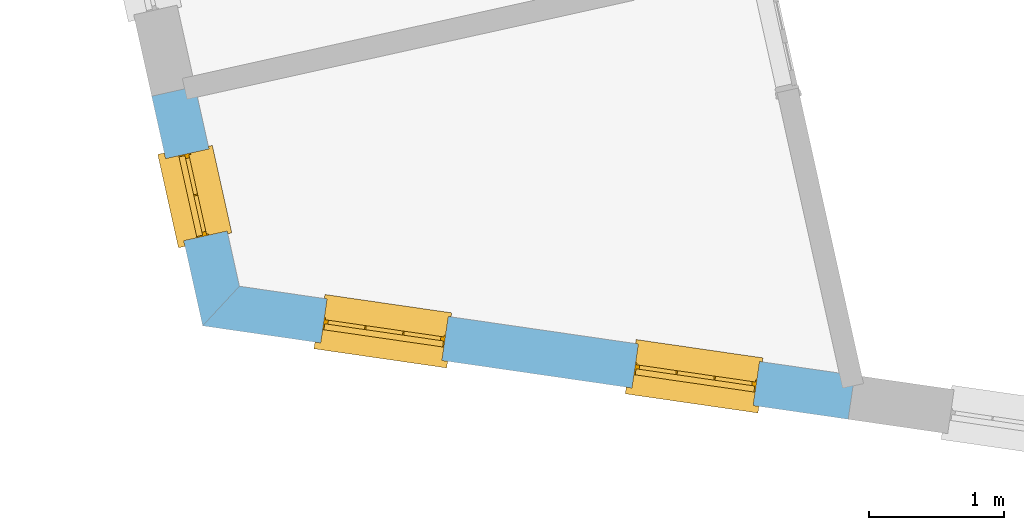
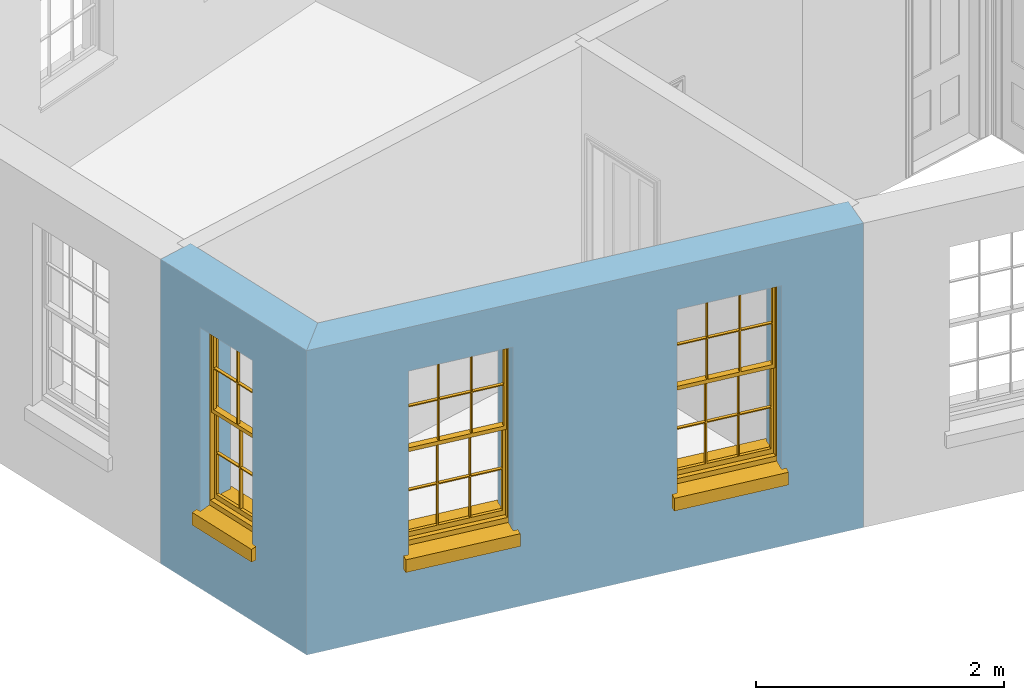
# One storey, part 2 of 10: 3 windows, 3 openings, plus 2 elements that do not belong to this part.
"""IFC2X3 building model written with IfcOpenShell, lengths in metres."""

from ifc_helpers import new_model, si_unit, frame, origin, place, context, subcontext, project, spatial, polyline, outline, extrude, faceted_brep, material, layer, layer_set, layer_usage, element, fill, save


model = new_model("IFC2X3")

# Units and contexts
model_context = context("Model", 3, world=origin())
body_context = subcontext(model_context, "Body", "Model", "MODEL_VIEW")
ifc_project = project(units=[si_unit("PLANEANGLEUNIT", "RADIAN"), si_unit("MASSUNIT", "GRAM", prefix="KILO"), si_unit("FORCEUNIT", "NEWTON", prefix="KILO"), si_unit("LENGTHUNIT", "METRE")], contexts=[model_context])

# Site, building, storey
site_placement = place(None, origin())
site = spatial("IfcSite", under=ifc_project, at=site_placement, CompositionType="ELEMENT")
building_placement = place(None, origin())
building = spatial("IfcBuilding", under=site, at=building_placement, Name="Building plot-16", CompositionType="ELEMENT")
storey_placement = place(None, frame((0.0, 0.0, 6.0)))
storey = spatial("IfcBuildingStorey", under=building, at=storey_placement, Name="Floor 1", CompositionType="ELEMENT", Elevation=6.0)

# Wall, opening, window
ifc_material = material(Name="Masonry")
ifc_layer = layer(ifc_material, 0.33, ventilated=False)
ifc_layer_set = layer_set([ifc_layer], Name="My Wall")
ifc_layer_usage = layer_usage(ifc_layer_set, "AXIS2", "NEGATIVE", 0.08)
wall_1_placement = place(storey_placement, origin())
wall_1 = element("IfcWallStandardCase", 1, at=wall_1_placement, inside=storey, material=ifc_layer_usage, Name="exterior", context=body_context, shape_type="SweptSolid", body=[
    extrude(outline(polyline([(87.6197813226672, 33.5557428221092), (87.2976082317312, 33.4842970421306), (87.6756142911979, 31.7797403754188), (87.9484434240576, 32.0736946856034), (87.6197813226672, 33.5557428221092)])), origin(), (0.0, 0.0, 1.0), 3.0),
])
opening_1_placement = place(storey_placement, frame((0.0, 0.0, 0.75)))
opening_1 = element("IfcOpeningElement", 2, at=opening_1_placement, cuts=wall_1, Name="Opening", ObjectType="Opening", context=body_context, shape_type="SweptSolid", body=[
    extrude(outline(polyline([(87.4002633796378, 33.0213903972391), (87.5355773568699, 32.4112140886482), (87.8577504478059, 32.4826598686268), (87.7224364705738, 33.0928361772177), (87.4002633796378, 33.0213903972391)])), origin(), (0.0, 0.0, 1.0), 1.82),
])
window_1_placement = place(storey_placement, frame((87.6443339030741, 33.075515988132, 0.75), z_axis=(0.0, 0.0, 1.0), x_axis=(0.135313977232144, -0.610176308590908, 0.0)))
window_1 = element("IfcWindow", 3, at=window_1_placement, inside=storey, Name="toilet outside window", OverallHeight=1.82, OverallWidth=0.625, context=body_context, shape_type="Brep", held_by="IfcProductRepresentation", body=[
    faceted_brep([(0.033125, -0.105, 0.975209), (0.01, -0.105, 0.975209), (0.033125, -0.105, 1.376042), (0.591875, -0.105, 0.975209), (0.591875, -0.105, 1.376042), (0.615, -0.105, 0.975209), (0.591875, -0.105, 1.386042), (0.591875, -0.105, 1.786875), (0.615, -0.105, 1.81), (0.033125, -0.105, 1.786875), (0.033125, -0.105, 1.386042), (0.01, -0.105, 1.81), (0.591875, -0.135, 1.376042), (0.591875, -0.135, 0.975209), (0.615, -0.135, 0.937083), (0.033125, -0.135, 1.786875), (0.01, -0.135, 1.81), (0.033125, -0.135, 1.386042), (0.01, -0.135, 0.937083), (0.033125, -0.135, 0.975209), (0.033125, -0.135, 1.376042), (0.591875, -0.135, 1.786875), (0.591875, -0.135, 1.386042), (0.615, -0.135, 1.81), (0.033125, -0.105, 0.937083), (0.01, -0.105, 0.937083), (0.033125, -0.105, 0.53625), (0.591875, -0.105, 0.937083), (0.591875, -0.105, 0.53625), (0.615, -0.105, 0.937083), (0.591875, -0.105, 0.52625), (0.591875, -0.105, 0.125417), (0.615, -0.105, 0.077167), (0.033125, -0.105, 0.125417), (0.033125, -0.105, 0.52625), (0.01, -0.105, 0.077167), (-0.0425, -0.25, 0.01), (-0.0425, -0.3, 0.001667), (0.0, -0.25, 0.01), (0.6675, -0.25, 0.01), (0.625, -0.25, 0.01), (0.6675, -0.3, 0.001667), (-0.02, 0.08, 0.077167), (0.0, 0.08, 0.077167), (-0.02, 0.11, 0.077167), (0.0, -0.06, 0.077167), (0.01, -0.06, 0.077167), (0.625, -0.06, 0.077167), (0.625, 0.08, 0.077167), (0.615, -0.06, 0.077167), (0.645, 0.08, 0.077167), (0.645, 0.11, 0.077167), (0.01, -0.075, 0.975209), (0.615, -0.075, 0.975209), (0.591875, -0.075, 0.125417), (0.591875, -0.075, 0.52625), (0.615, -0.075, 0.077167), (0.591875, -0.075, 0.53625), (0.591875, -0.075, 0.937083), (0.033125, -0.075, 0.125417), (0.01, -0.075, 0.077167), (0.033125, -0.075, 0.52625), (0.033125, -0.075, 0.937083), (0.033125, -0.075, 0.53625), (-0.02, 0.08, 0.052167), (-0.02, 0.11, 0.052167), (0.645, 0.11, 0.052167), (0.645, 0.08, 0.052167), (0.625, 0.08, 0.052167), (0.0, 0.08, 0.052167), (0.625, -0.15, 0.026667), (0.0, -0.15, 0.026667), (-0.0425, -0.3, -0.123333), (0.6675, -0.3, -0.123333), (-0.0425, -0.25, -0.123333), (0.6675, -0.25, -0.123333), (0.01, -0.06, 1.81), (0.615, -0.06, 1.81), (0.0, -0.06, 1.82), (0.625, -0.06, 1.82), (0.01, -0.15, 0.077167), (0.615, -0.15, 0.077167), (0.3175, -0.075, 0.53625), (0.3175, -0.105, 0.53625), (0.3175, -0.075, 0.52625), (0.3175, -0.075, 0.125417), (0.3075, -0.075, 0.125417), (0.3075, -0.075, 0.52625), (0.3075, -0.075, 0.53625), (0.3175, -0.075, 0.937083), (0.3075, -0.075, 0.937083), (0.3075, -0.105, 0.52625), (0.3075, -0.105, 0.125417), (0.3175, -0.105, 0.125417), (0.3175, -0.105, 0.52625), (0.3075, -0.105, 0.53625), (0.3075, -0.105, 0.937083), (0.3175, -0.105, 0.937083), (0.3075, -0.135, 1.386042), (0.3075, -0.135, 1.376042), (0.3175, -0.135, 1.376042), (0.3075, -0.135, 0.975209), (0.3175, -0.135, 0.975209), (0.3175, -0.135, 1.786875), (0.3075, -0.135, 1.786875), (0.3175, -0.135, 1.386042), (0.3175, -0.105, 1.386042), (0.3175, -0.105, 1.376042), (0.3075, -0.105, 1.386042), (0.3075, -0.105, 1.786875), (0.3175, -0.105, 1.786875), (0.3075, -0.105, 1.376042), (0.3175, -0.105, 0.975209), (0.3075, -0.105, 0.975209), (0.625, -0.15, 1.82), (0.615, -0.15, 1.81), (0.01, -0.15, 1.81), (0.0, -0.15, 1.82), (0.625, -0.25, 0.0), (0.0, -0.25, 0.0), (0.625, 0.08, 0.0), (0.0, 0.08, 0.0)], [[[0, 1, 2]], [[3, 4, 5]], [[6, 7, 8]], [[9, 10, 11]], [[12, 13, 14]], [[15, 16, 17]], [[18, 19, 20]], [[21, 22, 23]], [[24, 25, 26]], [[27, 28, 29]], [[30, 31, 32]], [[33, 34, 35]], [[14, 27, 29]], [[25, 24, 18]], [[36, 37, 38]], [[39, 40, 41]], [[42, 43, 44]], [[45, 46, 43]], [[47, 48, 49]], [[50, 51, 48]], [[1, 0, 52]], [[5, 53, 3]], [[54, 55, 56]], [[57, 58, 53]], [[59, 60, 61]], [[62, 63, 52]], [[48, 43, 46, 49]], [[51, 44, 43, 48]], [[64, 42, 44, 65]], [[65, 44, 51, 66]], [[66, 51, 50, 67]], [[65, 66, 68, 69]], [[60, 56, 49, 46]], [[70, 71, 38, 40]], [[37, 41, 40, 38]], [[37, 72, 73, 41]], [[74, 75, 73, 72]], [[8, 11, 76, 77]], [[76, 78, 79, 77]], [[32, 35, 80, 81]], [[81, 80, 71, 70]], [[28, 57, 82, 83]], [[84, 85, 86, 87]], [[88, 87, 61, 63]], [[89, 82, 88, 90]], [[84, 82, 57, 55]], [[91, 87, 86, 92]], [[34, 61, 87, 91]], [[93, 85, 84, 94]], [[95, 88, 63, 26]], [[96, 90, 88, 95]], [[83, 82, 89, 97]], [[94, 84, 55, 30]], [[94, 30, 28, 83]], [[94, 91, 92, 93]], [[95, 26, 34, 91]], [[97, 96, 95, 83]], [[98, 17, 20, 99]], [[100, 99, 101, 102]], [[103, 104, 98, 105]], [[100, 12, 22, 105]], [[106, 6, 4, 107]], [[106, 108, 109, 110]], [[111, 2, 10, 108]], [[112, 113, 111, 107]], [[99, 111, 113, 101]], [[20, 2, 111, 99]], [[102, 112, 107, 100]], [[98, 108, 10, 17]], [[104, 109, 108, 98]], [[105, 106, 110, 103]], [[22, 6, 106, 105]], [[100, 107, 4, 12]], [[82, 84, 87, 88]], [[83, 95, 91, 94]], [[99, 100, 105, 98]], [[107, 111, 108, 106]], [[92, 86, 59, 33]], [[15, 9, 109, 104]], [[103, 110, 7, 21]], [[31, 54, 85, 93]], [[36, 74, 72, 37]], [[39, 41, 73, 75]], [[18, 14, 102, 101]], [[23, 16, 104, 103]], [[85, 56, 60, 86]], [[52, 53, 89, 90]], [[53, 52, 113, 112]], [[11, 8, 110, 109]], [[14, 18, 96, 97]], [[2, 1, 11, 10]], [[8, 5, 4, 6]], [[57, 53, 56, 55]], [[60, 52, 63, 61]], [[26, 25, 35, 34]], [[32, 29, 28, 30]], [[14, 23, 22, 12]], [[18, 20, 17, 16]], [[19, 0, 2, 20]], [[17, 10, 9, 15]], [[12, 4, 3, 13]], [[21, 7, 6, 22]], [[27, 58, 57, 28]], [[30, 55, 54, 31]], [[33, 59, 61, 34]], [[26, 63, 62, 24]], [[5, 8, 77, 53]], [[76, 11, 1, 52]], [[46, 45, 78, 76]], [[49, 77, 79, 47]], [[70, 114, 115, 81]], [[71, 80, 116, 117]], [[19, 101, 113, 0]], [[102, 13, 3, 112]], [[90, 96, 24, 62]], [[29, 32, 81, 14]], [[80, 35, 25, 18]], [[60, 46, 76, 52]], [[77, 49, 56, 53]], [[23, 14, 81, 115]], [[16, 116, 80, 18]], [[92, 33, 35]], [[32, 31, 93]], [[32, 93, 92, 35]], [[14, 13, 102]], [[101, 19, 18]], [[103, 21, 23]], [[16, 15, 104]], [[109, 9, 11]], [[8, 7, 110]], [[23, 115, 116, 16]], [[114, 117, 116, 115]], [[90, 62, 52]], [[58, 89, 53]], [[27, 97, 89, 58]], [[85, 54, 56]], [[60, 59, 86]], [[97, 27, 14]], [[18, 24, 96]], [[52, 0, 113]], [[112, 3, 53]], [[79, 78, 117, 114]], [[78, 45, 71, 117]], [[114, 70, 47, 79]], [[118, 75, 74, 119]], [[68, 66, 67]], [[48, 68, 67, 50]], [[69, 64, 65]], [[42, 64, 69, 43]], [[69, 68, 120, 121]], [[70, 68, 48, 47]], [[118, 120, 68, 70]], [[43, 69, 71, 45]], [[69, 121, 119, 71]], [[120, 118, 119, 121]], [[38, 119, 74, 36]], [[71, 119, 38]], [[39, 75, 118, 40]], [[40, 118, 70]]]),
])
fill(opening_1, window_1)

# Wall, openings, windows
wall_2_placement = place(storey_placement, origin())
wall_2 = element("IfcWallStandardCase", 4, at=wall_2_placement, inside=storey, material=ifc_layer_usage, Name="exterior", context=body_context, shape_type="SweptSolid", body=[
    extrude(outline(polyline([(87.9484434240576, 32.0736946856034), (87.6756142911979, 31.7797403754188), (92.4666954104416, 31.086381689099), (92.513960177979, 31.4129793647637), (87.9484434240576, 32.0736946856034)])), origin(), (0.0, 0.0, 1.0), 3.0),
])
opening_2_placement = place(storey_placement, frame((0.0, 0.0, 0.75)))
opening_2 = element("IfcOpeningElement", 5, at=opening_2_placement, cuts=wall_2, Name="Opening", ObjectType="Opening", context=body_context, shape_type="SweptSolid", body=[
    extrude(outline(polyline([(88.5512372257678, 31.653021425663), (89.4518550586615, 31.5226852485144), (89.4991198261989, 31.8492829241791), (88.5985019933052, 31.9796191013278), (88.5512372257678, 31.653021425663)])), origin(), (0.0, 0.0, 1.0), 1.82),
])
opening_3_placement = place(storey_placement, frame((0.0, 0.0, 0.75)))
opening_3 = element("IfcOpeningElement", 6, at=opening_3_placement, cuts=wall_2, Name="Opening", ObjectType="Opening", context=body_context, shape_type="SweptSolid", body=[
    extrude(outline(polyline([(90.861336737919, 31.3187069936699), (91.7619545708128, 31.1883708165212), (91.8092193383502, 31.514968492186), (90.9086015054565, 31.6453046693347), (90.861336737919, 31.3187069936699)])), origin(), (0.0, 0.0, 1.0), 1.82),
])
window_2_placement = place(storey_placement, frame((88.5870438678416, 31.9004439072273, 0.75), z_axis=(0.0, 0.0, 1.0), x_axis=(0.900617832893758, -0.130336177148656, 0.0)))
window_2 = element("IfcWindow", 7, at=window_2_placement, inside=storey, Name="toilet outside window", OverallHeight=1.82, OverallWidth=0.91, context=body_context, shape_type="Brep", held_by="IfcProductRepresentation", body=[
    faceted_brep([(0.033125, -0.105, 0.975209), (0.01, -0.105, 0.975209), (0.033125, -0.105, 1.376042), (0.876875, -0.105, 0.975209), (0.876875, -0.105, 1.376042), (0.9, -0.105, 0.975209), (0.876875, -0.105, 1.386042), (0.876875, -0.105, 1.786875), (0.9, -0.105, 1.81), (0.033125, -0.105, 1.786875), (0.033125, -0.105, 1.386042), (0.01, -0.105, 1.81), (0.876875, -0.135, 1.376042), (0.876875, -0.135, 0.975209), (0.9, -0.135, 0.937083), (0.033125, -0.135, 1.786875), (0.01, -0.135, 1.81), (0.033125, -0.135, 1.386042), (0.01, -0.135, 0.937083), (0.033125, -0.135, 0.975209), (0.033125, -0.135, 1.376042), (0.876875, -0.135, 1.786875), (0.876875, -0.135, 1.386042), (0.9, -0.135, 1.81), (0.033125, -0.105, 0.937083), (0.01, -0.105, 0.937083), (0.033125, -0.105, 0.53625), (0.876875, -0.105, 0.937083), (0.876875, -0.105, 0.53625), (0.9, -0.105, 0.937083), (0.876875, -0.105, 0.52625), (0.876875, -0.105, 0.125417), (0.9, -0.105, 0.077167), (0.033125, -0.105, 0.125417), (0.033125, -0.105, 0.52625), (0.01, -0.105, 0.077167), (-0.0425, -0.25, 0.01), (-0.0425, -0.3, 0.001667), (0.0, -0.25, 0.01), (0.9525, -0.25, 0.01), (0.91, -0.25, 0.01), (0.9525, -0.3, 0.001667), (-0.02, 0.08, 0.077167), (0.0, 0.08, 0.077167), (-0.02, 0.11, 0.077167), (0.0, -0.06, 0.077167), (0.01, -0.06, 0.077167), (0.91, -0.06, 0.077167), (0.91, 0.08, 0.077167), (0.9, -0.06, 0.077167), (0.93, 0.08, 0.077167), (0.93, 0.11, 0.077167), (0.01, -0.075, 0.975209), (0.9, -0.075, 0.975209), (0.876875, -0.075, 0.125417), (0.876875, -0.075, 0.52625), (0.9, -0.075, 0.077167), (0.876875, -0.075, 0.53625), (0.876875, -0.075, 0.937083), (0.033125, -0.075, 0.125417), (0.01, -0.075, 0.077167), (0.033125, -0.075, 0.52625), (0.033125, -0.075, 0.937083), (0.033125, -0.075, 0.53625), (-0.02, 0.08, 0.052167), (-0.02, 0.11, 0.052167), (0.93, 0.11, 0.052167), (0.93, 0.08, 0.052167), (0.91, 0.08, 0.052167), (0.0, 0.08, 0.052167), (0.91, -0.15, 0.026667), (0.0, -0.15, 0.026667), (-0.0425, -0.3, -0.123333), (0.9525, -0.3, -0.123333), (-0.0425, -0.25, -0.123333), (0.9525, -0.25, -0.123333), (0.01, -0.06, 1.81), (0.9, -0.06, 1.81), (0.0, -0.06, 1.82), (0.91, -0.06, 1.82), (0.01, -0.15, 0.077167), (0.9, -0.15, 0.077167), (0.592292, -0.105, 0.125417), (0.592292, -0.075, 0.125417), (0.317708, -0.075, 0.125417), (0.317708, -0.105, 0.125417), (0.592292, -0.105, 0.53625), (0.317708, -0.105, 0.53625), (0.317708, -0.105, 0.52625), (0.592292, -0.105, 0.52625), (0.592292, -0.075, 0.53625), (0.317708, -0.075, 0.53625), (0.592292, -0.135, 1.386042), (0.592292, -0.105, 1.386042), (0.317708, -0.105, 1.386042), (0.317708, -0.135, 1.386042), (0.317708, -0.135, 1.376042), (0.592292, -0.135, 1.376042), (0.317708, -0.105, 1.376042), (0.592292, -0.105, 1.376042), (0.602292, -0.135, 1.376042), (0.592292, -0.135, 0.975209), (0.602292, -0.135, 0.975209), (0.602292, -0.105, 0.975209), (0.592292, -0.105, 0.975209), (0.602292, -0.105, 1.376042), (0.602292, -0.075, 0.53625), (0.602292, -0.105, 0.53625), (0.317708, -0.075, 0.52625), (0.307708, -0.075, 0.125417), (0.307708, -0.075, 0.52625), (0.602292, -0.075, 0.52625), (0.602292, -0.075, 0.125417), (0.592292, -0.075, 0.52625), (0.307708, -0.075, 0.53625), (0.317708, -0.075, 0.937083), (0.307708, -0.075, 0.937083), (0.602292, -0.075, 0.937083), (0.592292, -0.075, 0.937083), (0.307708, -0.105, 0.52625), (0.307708, -0.105, 0.125417), (0.307708, -0.105, 0.53625), (0.307708, -0.105, 0.937083), (0.592292, -0.105, 0.937083), (0.317708, -0.105, 0.937083), (0.602292, -0.105, 0.937083), (0.602292, -0.105, 0.52625), (0.602292, -0.105, 0.125417), (0.307708, -0.135, 1.386042), (0.307708, -0.135, 1.376042), (0.307708, -0.135, 0.975209), (0.317708, -0.135, 0.975209), (0.317708, -0.135, 1.786875), (0.307708, -0.135, 1.786875), (0.602292, -0.135, 1.786875), (0.592292, -0.135, 1.786875), (0.602292, -0.135, 1.386042), (0.602292, -0.105, 1.386042), (0.307708, -0.105, 1.386042), (0.307708, -0.105, 1.786875), (0.317708, -0.105, 1.786875), (0.592292, -0.105, 1.786875), (0.602292, -0.105, 1.786875), (0.307708, -0.105, 1.376042), (0.317708, -0.105, 0.975209), (0.307708, -0.105, 0.975209), (0.91, -0.15, 1.82), (0.9, -0.15, 1.81), (0.01, -0.15, 1.81), (0.0, -0.15, 1.82), (0.91, -0.25, 0.0), (0.0, -0.25, 0.0), (0.91, 0.08, 0.0), (0.0, 0.08, 0.0)], [[[0, 1, 2]], [[3, 4, 5]], [[6, 7, 8]], [[9, 10, 11]], [[12, 13, 14]], [[15, 16, 17]], [[18, 19, 20]], [[21, 22, 23]], [[24, 25, 26]], [[27, 28, 29]], [[30, 31, 32]], [[33, 34, 35]], [[14, 27, 29]], [[25, 24, 18]], [[36, 37, 38]], [[39, 40, 41]], [[42, 43, 44]], [[45, 46, 43]], [[47, 48, 49]], [[50, 51, 48]], [[1, 0, 52]], [[5, 53, 3]], [[54, 55, 56]], [[57, 58, 53]], [[59, 60, 61]], [[62, 63, 52]], [[48, 43, 46, 49]], [[51, 44, 43, 48]], [[64, 42, 44, 65]], [[65, 44, 51, 66]], [[66, 51, 50, 67]], [[65, 66, 68, 69]], [[60, 56, 49, 46]], [[70, 71, 38, 40]], [[37, 41, 40, 38]], [[37, 72, 73, 41]], [[74, 75, 73, 72]], [[8, 11, 76, 77]], [[76, 78, 79, 77]], [[32, 35, 80, 81]], [[81, 80, 71, 70]], [[82, 83, 84, 85]], [[86, 87, 88, 89]], [[86, 90, 91, 87]], [[92, 93, 94, 95]], [[92, 95, 96, 97]], [[96, 98, 99, 97]], [[100, 97, 101, 102]], [[103, 104, 99, 105]], [[97, 99, 104, 101]], [[102, 103, 105, 100]], [[28, 57, 106, 107]], [[108, 84, 109, 110]], [[111, 112, 83, 113]], [[114, 110, 61, 63]], [[90, 113, 108, 91]], [[115, 91, 114, 116]], [[117, 106, 90, 118]], [[111, 106, 57, 55]], [[119, 110, 109, 120]], [[34, 61, 110, 119]], [[89, 113, 83, 82]], [[88, 108, 113, 89]], [[85, 84, 108, 88]], [[121, 114, 63, 26]], [[122, 116, 114, 121]], [[123, 118, 90, 86]], [[87, 91, 115, 124]], [[107, 106, 117, 125]], [[126, 111, 55, 30]], [[127, 112, 111, 126]], [[126, 30, 28, 107]], [[88, 119, 120, 85]], [[126, 89, 82, 127]], [[125, 123, 86, 107]], [[121, 26, 34, 119]], [[124, 122, 121, 87]], [[128, 17, 20, 129]], [[96, 129, 130, 131]], [[132, 133, 128, 95]], [[134, 135, 92, 136]], [[100, 12, 22, 136]], [[137, 6, 4, 105]], [[94, 138, 139, 140]], [[137, 93, 141, 142]], [[99, 98, 94, 93]], [[143, 2, 10, 138]], [[144, 145, 143, 98]], [[129, 143, 145, 130]], [[20, 2, 143, 129]], [[131, 144, 98, 96]], [[128, 138, 10, 17]], [[133, 139, 138, 128]], [[135, 141, 93, 92]], [[95, 94, 140, 132]], [[22, 6, 137, 136]], [[136, 137, 142, 134]], [[100, 105, 4, 12]], [[107, 86, 89, 126]], [[106, 111, 113, 90]], [[91, 108, 110, 114]], [[87, 121, 119, 88]], [[97, 100, 136, 92]], [[129, 96, 95, 128]], [[98, 143, 138, 94]], [[105, 99, 93, 137]], [[131, 101, 104, 144]], [[124, 115, 118, 123]], [[132, 140, 141, 135]], [[120, 109, 59, 33]], [[15, 9, 139, 133]], [[134, 142, 7, 21]], [[31, 54, 112, 127]], [[36, 74, 72, 37]], [[39, 41, 73, 75]], [[18, 14, 101, 131]], [[23, 16, 132, 135]], [[83, 56, 60, 84]], [[52, 53, 118, 115]], [[53, 52, 144, 104]], [[11, 8, 141, 140]], [[14, 18, 124, 123]], [[2, 1, 11, 10]], [[8, 5, 4, 6]], [[57, 53, 56, 55]], [[60, 52, 63, 61]], [[26, 25, 35, 34]], [[32, 29, 28, 30]], [[14, 23, 22, 12]], [[18, 20, 17, 16]], [[19, 0, 2, 20]], [[17, 10, 9, 15]], [[12, 4, 3, 13]], [[21, 7, 6, 22]], [[27, 58, 57, 28]], [[30, 55, 54, 31]], [[33, 59, 61, 34]], [[26, 63, 62, 24]], [[5, 8, 77, 53]], [[76, 11, 1, 52]], [[46, 45, 78, 76]], [[49, 77, 79, 47]], [[70, 146, 147, 81]], [[71, 80, 148, 149]], [[19, 130, 145, 0]], [[102, 13, 3, 103]], [[116, 122, 24, 62]], [[29, 32, 81, 14]], [[80, 35, 25, 18]], [[60, 46, 76, 52]], [[77, 49, 56, 53]], [[23, 14, 81, 147]], [[16, 148, 80, 18]], [[35, 85, 120]], [[120, 33, 35]], [[127, 82, 32]], [[32, 31, 127]], [[32, 82, 85, 35]], [[102, 101, 14]], [[14, 13, 102]], [[18, 131, 130]], [[130, 19, 18]], [[134, 21, 23]], [[23, 135, 134]], [[16, 15, 133]], [[133, 132, 16]], [[11, 140, 139]], [[139, 9, 11]], [[142, 141, 8]], [[8, 7, 142]], [[23, 147, 148, 16]], [[146, 149, 148, 147]], [[52, 115, 116]], [[116, 62, 52]], [[118, 53, 117]], [[58, 117, 53]], [[27, 125, 117, 58]], [[56, 83, 112]], [[112, 54, 56]], [[109, 84, 60]], [[60, 59, 109]], [[125, 27, 14]], [[14, 123, 125]], [[122, 124, 18]], [[18, 24, 122]], [[145, 144, 52]], [[52, 0, 145]], [[103, 3, 53]], [[53, 104, 103]], [[79, 78, 149, 146]], [[78, 45, 71, 149]], [[146, 70, 47, 79]], [[150, 75, 74, 151]], [[68, 66, 67]], [[48, 68, 67, 50]], [[69, 64, 65]], [[42, 64, 69, 43]], [[69, 68, 152, 153]], [[70, 68, 48, 47]], [[150, 152, 68, 70]], [[43, 69, 71, 45]], [[69, 153, 151, 71]], [[152, 150, 151, 153]], [[38, 151, 74, 36]], [[71, 151, 38]], [[39, 75, 150, 40]], [[40, 150, 70]]]),
])
fill(opening_2, window_2)
window_3_placement = place(storey_placement, frame((90.8971433799929, 31.5661294752341, 0.75), z_axis=(0.0, 0.0, 1.0), x_axis=(0.900617832893772, -0.130336177148656, 0.0)))
window_3 = element("IfcWindow", 8, at=window_3_placement, inside=storey, Name="toilet outside window", OverallHeight=1.82, OverallWidth=0.91, context=body_context, shape_type="Brep", held_by="IfcProductRepresentation", body=[
    faceted_brep([(0.033125, -0.105, 0.975209), (0.01, -0.105, 0.975209), (0.033125, -0.105, 1.376042), (0.876875, -0.105, 0.975209), (0.876875, -0.105, 1.376042), (0.9, -0.105, 0.975209), (0.876875, -0.105, 1.386042), (0.876875, -0.105, 1.786875), (0.9, -0.105, 1.81), (0.033125, -0.105, 1.786875), (0.033125, -0.105, 1.386042), (0.01, -0.105, 1.81), (0.876875, -0.135, 1.376042), (0.876875, -0.135, 0.975209), (0.9, -0.135, 0.937083), (0.033125, -0.135, 1.786875), (0.01, -0.135, 1.81), (0.033125, -0.135, 1.386042), (0.01, -0.135, 0.937083), (0.033125, -0.135, 0.975209), (0.033125, -0.135, 1.376042), (0.876875, -0.135, 1.786875), (0.876875, -0.135, 1.386042), (0.9, -0.135, 1.81), (0.033125, -0.105, 0.937083), (0.01, -0.105, 0.937083), (0.033125, -0.105, 0.53625), (0.876875, -0.105, 0.937083), (0.876875, -0.105, 0.53625), (0.9, -0.105, 0.937083), (0.876875, -0.105, 0.52625), (0.876875, -0.105, 0.125417), (0.9, -0.105, 0.077167), (0.033125, -0.105, 0.125417), (0.033125, -0.105, 0.52625), (0.01, -0.105, 0.077167), (-0.0425, -0.25, 0.01), (-0.0425, -0.3, 0.001667), (0.0, -0.25, 0.01), (0.9525, -0.25, 0.01), (0.91, -0.25, 0.01), (0.9525, -0.3, 0.001667), (-0.02, 0.08, 0.077167), (0.0, 0.08, 0.077167), (-0.02, 0.11, 0.077167), (0.0, -0.06, 0.077167), (0.01, -0.06, 0.077167), (0.91, -0.06, 0.077167), (0.91, 0.08, 0.077167), (0.9, -0.06, 0.077167), (0.93, 0.08, 0.077167), (0.93, 0.11, 0.077167), (0.01, -0.075, 0.975209), (0.9, -0.075, 0.975209), (0.876875, -0.075, 0.125417), (0.876875, -0.075, 0.52625), (0.9, -0.075, 0.077167), (0.876875, -0.075, 0.53625), (0.876875, -0.075, 0.937083), (0.033125, -0.075, 0.125417), (0.01, -0.075, 0.077167), (0.033125, -0.075, 0.52625), (0.033125, -0.075, 0.937083), (0.033125, -0.075, 0.53625), (-0.02, 0.08, 0.052167), (-0.02, 0.11, 0.052167), (0.93, 0.11, 0.052167), (0.93, 0.08, 0.052167), (0.91, 0.08, 0.052167), (0.0, 0.08, 0.052167), (0.91, -0.15, 0.026667), (0.0, -0.15, 0.026667), (-0.0425, -0.3, -0.123333), (0.9525, -0.3, -0.123333), (-0.0425, -0.25, -0.123333), (0.9525, -0.25, -0.123333), (0.01, -0.06, 1.81), (0.9, -0.06, 1.81), (0.0, -0.06, 1.82), (0.91, -0.06, 1.82), (0.01, -0.15, 0.077167), (0.9, -0.15, 0.077167), (0.592292, -0.105, 0.125417), (0.592292, -0.075, 0.125417), (0.317708, -0.075, 0.125417), (0.317708, -0.105, 0.125417), (0.592292, -0.105, 0.53625), (0.317708, -0.105, 0.53625), (0.317708, -0.105, 0.52625), (0.592292, -0.105, 0.52625), (0.592292, -0.075, 0.53625), (0.317708, -0.075, 0.53625), (0.592292, -0.135, 1.386042), (0.592292, -0.105, 1.386042), (0.317708, -0.105, 1.386042), (0.317708, -0.135, 1.386042), (0.317708, -0.135, 1.376042), (0.592292, -0.135, 1.376042), (0.317708, -0.105, 1.376042), (0.592292, -0.105, 1.376042), (0.602292, -0.135, 1.376042), (0.592292, -0.135, 0.975209), (0.602292, -0.135, 0.975209), (0.602292, -0.105, 0.975209), (0.592292, -0.105, 0.975209), (0.602292, -0.105, 1.376042), (0.602292, -0.075, 0.53625), (0.602292, -0.105, 0.53625), (0.317708, -0.075, 0.52625), (0.307708, -0.075, 0.125417), (0.307708, -0.075, 0.52625), (0.602292, -0.075, 0.52625), (0.602292, -0.075, 0.125417), (0.592292, -0.075, 0.52625), (0.307708, -0.075, 0.53625), (0.317708, -0.075, 0.937083), (0.307708, -0.075, 0.937083), (0.602292, -0.075, 0.937083), (0.592292, -0.075, 0.937083), (0.307708, -0.105, 0.52625), (0.307708, -0.105, 0.125417), (0.307708, -0.105, 0.53625), (0.307708, -0.105, 0.937083), (0.592292, -0.105, 0.937083), (0.317708, -0.105, 0.937083), (0.602292, -0.105, 0.937083), (0.602292, -0.105, 0.52625), (0.602292, -0.105, 0.125417), (0.307708, -0.135, 1.386042), (0.307708, -0.135, 1.376042), (0.307708, -0.135, 0.975209), (0.317708, -0.135, 0.975209), (0.317708, -0.135, 1.786875), (0.307708, -0.135, 1.786875), (0.602292, -0.135, 1.786875), (0.592292, -0.135, 1.786875), (0.602292, -0.135, 1.386042), (0.602292, -0.105, 1.386042), (0.307708, -0.105, 1.386042), (0.307708, -0.105, 1.786875), (0.317708, -0.105, 1.786875), (0.592292, -0.105, 1.786875), (0.602292, -0.105, 1.786875), (0.307708, -0.105, 1.376042), (0.317708, -0.105, 0.975209), (0.307708, -0.105, 0.975209), (0.91, -0.15, 1.82), (0.9, -0.15, 1.81), (0.01, -0.15, 1.81), (0.0, -0.15, 1.82), (0.91, -0.25, 0.0), (0.0, -0.25, 0.0), (0.91, 0.08, 0.0), (0.0, 0.08, 0.0)], [[[0, 1, 2]], [[3, 4, 5]], [[6, 7, 8]], [[9, 10, 11]], [[12, 13, 14]], [[15, 16, 17]], [[18, 19, 20]], [[21, 22, 23]], [[24, 25, 26]], [[27, 28, 29]], [[30, 31, 32]], [[33, 34, 35]], [[14, 27, 29]], [[25, 24, 18]], [[36, 37, 38]], [[39, 40, 41]], [[42, 43, 44]], [[45, 46, 43]], [[47, 48, 49]], [[50, 51, 48]], [[1, 0, 52]], [[5, 53, 3]], [[54, 55, 56]], [[57, 58, 53]], [[59, 60, 61]], [[62, 63, 52]], [[48, 43, 46, 49]], [[51, 44, 43, 48]], [[64, 42, 44, 65]], [[65, 44, 51, 66]], [[66, 51, 50, 67]], [[65, 66, 68, 69]], [[60, 56, 49, 46]], [[70, 71, 38, 40]], [[37, 41, 40, 38]], [[37, 72, 73, 41]], [[74, 75, 73, 72]], [[8, 11, 76, 77]], [[76, 78, 79, 77]], [[32, 35, 80, 81]], [[81, 80, 71, 70]], [[82, 83, 84, 85]], [[86, 87, 88, 89]], [[86, 90, 91, 87]], [[92, 93, 94, 95]], [[92, 95, 96, 97]], [[96, 98, 99, 97]], [[100, 97, 101, 102]], [[103, 104, 99, 105]], [[97, 99, 104, 101]], [[102, 103, 105, 100]], [[28, 57, 106, 107]], [[108, 84, 109, 110]], [[111, 112, 83, 113]], [[114, 110, 61, 63]], [[90, 113, 108, 91]], [[115, 91, 114, 116]], [[117, 106, 90, 118]], [[111, 106, 57, 55]], [[119, 110, 109, 120]], [[34, 61, 110, 119]], [[89, 113, 83, 82]], [[88, 108, 113, 89]], [[85, 84, 108, 88]], [[121, 114, 63, 26]], [[122, 116, 114, 121]], [[123, 118, 90, 86]], [[87, 91, 115, 124]], [[107, 106, 117, 125]], [[126, 111, 55, 30]], [[127, 112, 111, 126]], [[126, 30, 28, 107]], [[88, 119, 120, 85]], [[126, 89, 82, 127]], [[125, 123, 86, 107]], [[121, 26, 34, 119]], [[124, 122, 121, 87]], [[128, 17, 20, 129]], [[96, 129, 130, 131]], [[132, 133, 128, 95]], [[134, 135, 92, 136]], [[100, 12, 22, 136]], [[137, 6, 4, 105]], [[94, 138, 139, 140]], [[137, 93, 141, 142]], [[99, 98, 94, 93]], [[143, 2, 10, 138]], [[144, 145, 143, 98]], [[129, 143, 145, 130]], [[20, 2, 143, 129]], [[131, 144, 98, 96]], [[128, 138, 10, 17]], [[133, 139, 138, 128]], [[135, 141, 93, 92]], [[95, 94, 140, 132]], [[22, 6, 137, 136]], [[136, 137, 142, 134]], [[100, 105, 4, 12]], [[107, 86, 89, 126]], [[106, 111, 113, 90]], [[91, 108, 110, 114]], [[87, 121, 119, 88]], [[97, 100, 136, 92]], [[129, 96, 95, 128]], [[98, 143, 138, 94]], [[105, 99, 93, 137]], [[131, 101, 104, 144]], [[124, 115, 118, 123]], [[132, 140, 141, 135]], [[120, 109, 59, 33]], [[15, 9, 139, 133]], [[134, 142, 7, 21]], [[31, 54, 112, 127]], [[36, 74, 72, 37]], [[39, 41, 73, 75]], [[18, 14, 101, 131]], [[23, 16, 132, 135]], [[83, 56, 60, 84]], [[52, 53, 118, 115]], [[53, 52, 144, 104]], [[11, 8, 141, 140]], [[14, 18, 124, 123]], [[2, 1, 11, 10]], [[8, 5, 4, 6]], [[57, 53, 56, 55]], [[60, 52, 63, 61]], [[26, 25, 35, 34]], [[32, 29, 28, 30]], [[14, 23, 22, 12]], [[18, 20, 17, 16]], [[19, 0, 2, 20]], [[17, 10, 9, 15]], [[12, 4, 3, 13]], [[21, 7, 6, 22]], [[27, 58, 57, 28]], [[30, 55, 54, 31]], [[33, 59, 61, 34]], [[26, 63, 62, 24]], [[5, 8, 77, 53]], [[76, 11, 1, 52]], [[46, 45, 78, 76]], [[49, 77, 79, 47]], [[70, 146, 147, 81]], [[71, 80, 148, 149]], [[19, 130, 145, 0]], [[102, 13, 3, 103]], [[116, 122, 24, 62]], [[29, 32, 81, 14]], [[80, 35, 25, 18]], [[60, 46, 76, 52]], [[77, 49, 56, 53]], [[23, 14, 81, 147]], [[16, 148, 80, 18]], [[35, 85, 120]], [[120, 33, 35]], [[127, 82, 32]], [[32, 31, 127]], [[32, 82, 85, 35]], [[102, 101, 14]], [[14, 13, 102]], [[18, 131, 130]], [[130, 19, 18]], [[134, 21, 23]], [[23, 135, 134]], [[16, 15, 133]], [[133, 132, 16]], [[11, 140, 139]], [[139, 9, 11]], [[142, 141, 8]], [[8, 7, 142]], [[23, 147, 148, 16]], [[146, 149, 148, 147]], [[52, 115, 116]], [[116, 62, 52]], [[118, 53, 117]], [[58, 117, 53]], [[27, 125, 117, 58]], [[56, 83, 112]], [[112, 54, 56]], [[109, 84, 60]], [[60, 59, 109]], [[125, 27, 14]], [[14, 123, 125]], [[122, 124, 18]], [[18, 24, 122]], [[145, 144, 52]], [[52, 0, 145]], [[103, 3, 53]], [[53, 104, 103]], [[79, 78, 149, 146]], [[78, 45, 71, 149]], [[146, 70, 47, 79]], [[150, 75, 74, 151]], [[68, 66, 67]], [[48, 68, 67, 50]], [[69, 64, 65]], [[42, 64, 69, 43]], [[69, 68, 152, 153]], [[70, 68, 48, 47]], [[150, 152, 68, 70]], [[43, 69, 71, 45]], [[69, 153, 151, 71]], [[152, 150, 151, 153]], [[38, 151, 74, 36]], [[71, 151, 38]], [[39, 75, 150, 40]], [[40, 150, 70]]]),
])
fill(opening_3, window_3)

save(model, "model.ifc")
